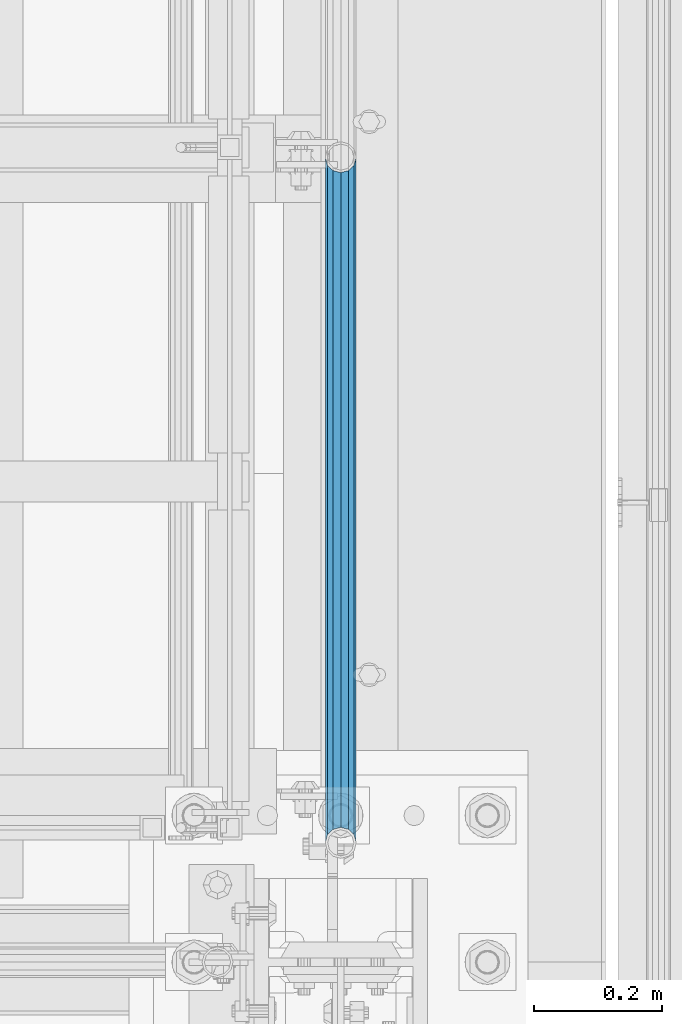
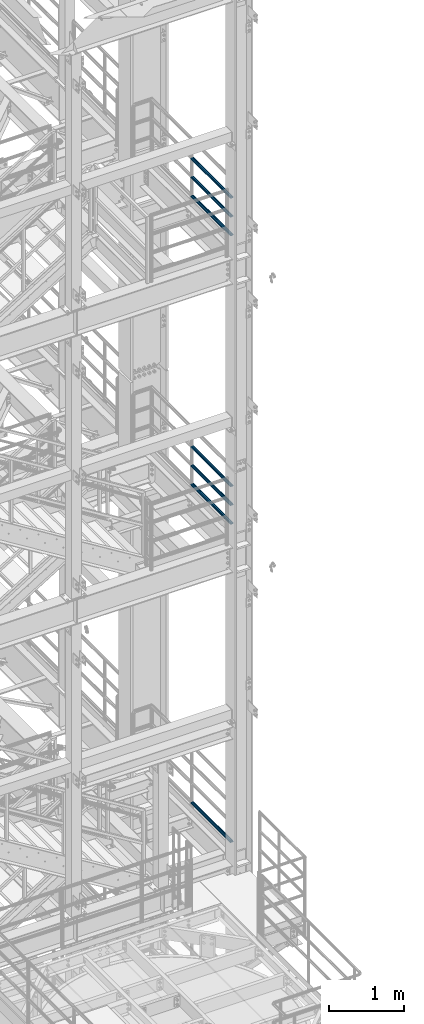
# One storey, part 999 of 1876: 7 beams, 3 elements without a shape of their own.
"""IFC2X3 building model written with IfcOpenShell, lengths in millimetres."""

from ifc_helpers import new_model, si_unit, frame, origin_with_axes, place, context, subcontext, project, spatial, faceted_brep, material, type_object, element, aggregate, save


model = new_model("IFC2X3")

# Units and contexts
model_context = context("Model", 3, precision=1e-05, world=origin_with_axes())
body_context = subcontext(model_context, "Body", "Model", "MODEL_VIEW")
ifc_project = project(units=[si_unit("LENGTHUNIT", "METRE", prefix="MILLI"), si_unit("AREAUNIT", "SQUARE_METRE"), si_unit("VOLUMEUNIT", "CUBIC_METRE"), si_unit("MASSUNIT", "GRAM", prefix="KILO"), si_unit("TIMEUNIT", "SECOND"), si_unit("PLANEANGLEUNIT", "RADIAN"), si_unit("SOLIDANGLEUNIT", "STERADIAN"), si_unit("THERMODYNAMICTEMPERATUREUNIT", "DEGREE_CELSIUS"), si_unit("LUMINOUSINTENSITYUNIT", "LUMEN")], contexts=[model_context])

# Site, building, storey
site_placement = place(None, origin_with_axes())
site = spatial("IfcSite", under=ifc_project, at=site_placement, CompositionType="ELEMENT")
building_placement = place(site_placement, origin_with_axes())
building = spatial("IfcBuilding", under=site, at=building_placement, Name="Undefined", CompositionType="ELEMENT")
storey_placement = place(building_placement, origin_with_axes())
storey = spatial("IfcBuildingStorey", under=building, at=storey_placement, Name="Undefined", CompositionType="ELEMENT", Elevation=0.0)

# Assembly, beams
assembly_1_placement = place(storey_placement, origin_with_axes())
assembly_1 = element("IfcElementAssembly", 1, at=assembly_1_placement, inside=storey, Name="RAIL", AssemblyPlace="NOTDEFINED", PredefinedType="RIGID_FRAME")
ifc_material = material()
beam_type = type_object("IfcBeamType", Name="PIPE1-1/2SCH40", PredefinedType="NOTDEFINED")
beam_1_placement = place(assembly_1_placement, frame((7620.00000000003, -5857.08124999999, 18145.125), z_axis=(0.0, 0.0, 1.0), x_axis=(0.0, -1.0, 0.0)))
beam_1 = element("IfcBeam", 2, at=beam_1_placement, type_object=beam_type, material=ifc_material, Name="RAIL", ObjectType="PIPE1-1/2SCH40", context=body_context, shape_type="Brep", body=[
    faceted_brep([(1047.96655700668, -12.0649999999996, 20.8971929933177), (1047.96655700668, -12.0649999999787, 15.8661214312015), (1047.47312856882, -10.2235000000001, 17.7076214311819), (1044.73375, 9.09494701772928e-13, 20.4470000000001), (1044.73375, 9.09494701772928e-13, 24.130000000001), (1047.47312856881, 10.2235000000001, 17.7076214311819), (1047.96655700668, 12.0650000000205, 15.8661214311578), (1047.96655700668, 12.0649999999996, 20.8971929933177), (1068.86375, 24.1300000000001, 0.0), (1056.79875, 20.8971929933186, 12.0649999999987), (1056.79875, 20.8971929933186, -12.0649999999987), (1053.60917843784, 17.7076214311801, 10.2235000000001), (1056.34855700666, 20.4470000000001, 0.0), (1053.60917843784, 17.7076214311801, -10.2235000000001), (1047.96655700668, 12.0650000000205, -15.8661214311578), (1047.96655700668, 12.0649999999996, -20.8971929933177), (1047.47312856881, 10.2235000000001, -17.7076214311819), (1044.73375, 0.0, -20.4470000000001), (1044.73375, 0.0, -24.130000000001), (1047.96655700668, -12.0649999999787, -15.8661214312015), (1047.96655700668, -12.0649999999996, -20.8971929933177), (1047.47312856882, -10.2235000000001, -17.7076214311819), (1068.86375, -24.1299999999792, 0.0), (1056.79875, -20.8971929933186, -12.0649999999987), (1056.79875, -20.8971929933186, 12.0649999999987), (1053.60917843788, -17.7076214311801, -10.2235000000001), (1056.3485570067, -20.4470000000001, 0.0), (1053.60917843788, -17.7076214311801, 10.2235000000001), (12.0650000000064, -20.8971929933177, -12.0649999999987), (20.8971929933249, -12.0650000000005, -20.8971929933177), (0.0, 24.1299999999992, 0.0), (12.0650000000064, 20.8971929933177, -12.0649999999987), (12.0650000000064, 20.8971929933177, 12.0649999999987), (20.8971929933249, 12.0650000000005, 20.8971929933177), (24.1300000000064, 0.0, 24.130000000001), (20.8971929933249, 12.0650000000005, -20.8971929933177), (24.1300000000063, 0.0, -24.130000000001), (24.1300000000063, 0.0, -20.4470000000001), (20.8971929933249, -12.0650000000005, -15.8661214311796), (21.3906214311868, -10.2235000000001, -17.7076214311819), (21.3906214311868, 10.2235000000001, -17.7076214311819), (20.8971929933249, 12.0650000000005, -15.8661214311796), (15.2545715621445, 17.7076214311801, -10.2235000000001), (12.5151929933249, 20.4470000000001, 0.0), (15.2545715621445, 17.7076214311801, 10.2235000000001), (20.8971929933249, 12.0650000000005, 15.8661214311796), (21.3906214311868, 10.2235000000001, 17.7076214311819), (24.1300000000064, 0.0, 20.4470000000001), (21.3906214311868, -10.2235000000001, 17.7076214311819), (20.8971929933249, -12.0650000000005, 15.8661214311796), (20.8971929933249, -12.0650000000005, 20.8971929933177), (12.0650000000064, -20.8971929933177, 12.0649999999987), (0.0, -24.1299999999992, 0.0), (15.2545715621445, -17.7076214311801, 10.2235000000001), (12.5151929933249, -20.4470000000001, 0.0), (15.2545715621445, -17.7076214311801, -10.2235000000001)], [[[0, 1, 2, 3, 4]], [[4, 3, 5, 6, 7]], [[8, 9, 10]], [[7, 6, 11, 12, 13, 14, 15, 10, 9]], [[16, 17, 18, 15, 14]], [[19, 20, 18, 17, 21]], [[22, 23, 24]], [[24, 23, 20, 19, 25, 26, 27, 1, 0]], [[28, 29, 20, 23]], [[30, 31, 32]], [[33, 34, 4, 7]], [[32, 33, 7, 9]], [[30, 32, 9, 8]], [[31, 30, 8, 10]], [[35, 31, 10, 15]], [[36, 35, 15, 18]], [[29, 36, 18, 20]], [[37, 36, 29, 38, 39]], [[40, 41, 35, 36, 37]], [[32, 31, 35, 41, 42, 43, 44, 45, 33]], [[33, 45, 46, 47, 34]], [[34, 47, 48, 49, 50]], [[34, 50, 0, 4]], [[50, 51, 24, 0]], [[51, 52, 22, 24]], [[52, 28, 23, 22]], [[51, 28, 52]], [[50, 49, 53, 54, 55, 38, 29, 28, 51]], [[55, 54, 26, 25]], [[21, 39, 38, 55, 25, 19]], [[37, 39, 21, 17]], [[40, 37, 17, 16]], [[42, 41, 40, 16, 14, 13]], [[43, 42, 13, 12]], [[44, 43, 12, 11]], [[5, 46, 45, 44, 11, 6]], [[47, 46, 5, 3]], [[48, 47, 3, 2]], [[53, 49, 48, 2, 1, 27]], [[54, 53, 27, 26]]]),
])
beam_2_placement = place(assembly_1_placement, frame((7620.00000000003, -6925.94499999999, 18449.925), z_axis=(0.0, 0.0, -1.0), x_axis=(0.0, 1.0, 0.0)))
beam_2 = element("IfcBeam", 3, at=beam_2_placement, type_object=beam_type, material=ifc_material, Name="RAIL", ObjectType="PIPE1-1/2SCH40", context=body_context, shape_type="Brep", body=[
    faceted_brep([(0.0, 24.1299999999992, 0.0), (12.0650000000064, 20.8971929933177, -12.0649999999987), (12.0650000000064, 20.8971929933177, 12.0649999999987), (12.0650000000064, -20.8971929933177, 12.0649999999987), (12.0650000000064, -20.8971929933177, -12.0649999999987), (0.0, -24.1299999999992, 0.0), (20.8971929933249, -12.0650000000005, 20.8971929933177), (20.8971929933249, -12.0650000000005, 15.8661214311796), (15.2545715621445, -17.7076214311801, 10.2235000000001), (12.5151929933249, -20.4470000000001, 0.0), (15.2545715621445, -17.7076214311801, -10.2235000000001), (20.8971929933249, -12.0650000000005, -15.8661214311796), (20.8971929933249, -12.0650000000005, -20.8971929933177), (24.1300000000063, 0.0, -20.4470000000001), (24.1300000000063, 0.0, -24.130000000001), (21.3906214311868, -10.2235000000001, -17.7076214311819), (21.3906214311868, 10.2235000000001, -17.7076214311819), (20.8971929933249, 12.0650000000005, -15.8661214311796), (20.8971929933249, 12.0650000000005, -20.8971929933177), (15.2545715621445, 17.7076214311801, -10.2235000000001), (12.5151929933249, 20.4470000000001, 0.0), (15.2545715621445, 17.7076214311801, 10.2235000000001), (20.8971929933249, 12.0650000000005, 15.8661214311796), (20.8971929933249, 12.0650000000005, 20.8971929933177), (21.3906214311868, 10.2235000000001, 17.7076214311819), (24.1300000000064, 0.0, 20.4470000000001), (24.1300000000064, 0.0, 24.130000000001), (21.3906214311868, -10.2235000000001, 17.7076214311819), (1068.86375, 24.1300000000001, 0.0), (1056.79875, 20.8971929933186, -12.0649999999987), (1047.96655700668, 12.0649999999996, -20.8971929933177), (1068.86375, -24.1299999999792, 0.0), (1056.79875, -20.8971929933186, -12.0649999999987), (1056.79875, -20.8971929933186, 12.0649999999987), (1047.96655700668, -12.0649999999996, 20.8971929933177), (1047.96655700668, -12.0649999999996, -20.8971929933177), (1044.73375, 0.0, -24.130000000001), (1047.47312856881, 10.2235000000001, -17.7076214311819), (1044.73375, 0.0, -20.4470000000001), (1047.96655700668, 12.0650000000205, -15.8661214311578), (1047.96655700668, -12.0649999999787, -15.8661214312015), (1047.47312856882, -10.2235000000001, -17.7076214311819), (1053.60917843788, -17.7076214311801, -10.2235000000001), (1056.3485570067, -20.4470000000001, 0.0), (1053.60917843788, -17.7076214311801, 10.2235000000001), (1047.96655700668, -12.0649999999787, 15.8661214312015), (1047.47312856882, -10.2235000000001, 17.7076214311819), (1044.73375, 9.09494701772928e-13, 20.4470000000001), (1044.73375, 9.09494701772928e-13, 24.130000000001), (1047.96655700668, 12.0649999999996, 20.8971929933177), (1056.79875, 20.8971929933186, 12.0649999999987), (1047.96655700668, 12.0650000000205, 15.8661214311578), (1053.60917843784, 17.7076214311801, 10.2235000000001), (1056.34855700666, 20.4470000000001, 0.0), (1053.60917843784, 17.7076214311801, -10.2235000000001), (1047.47312856881, 10.2235000000001, 17.7076214311819)], [[[0, 1, 2]], [[3, 4, 5]], [[6, 7, 8, 9, 10, 11, 12, 4, 3]], [[13, 14, 12, 11, 15]], [[16, 17, 18, 14, 13]], [[2, 1, 18, 17, 19, 20, 21, 22, 23]], [[23, 22, 24, 25, 26]], [[26, 25, 27, 7, 6]], [[1, 0, 28, 29]], [[18, 1, 29, 30]], [[31, 32, 33]], [[6, 3, 33, 34]], [[3, 5, 31, 33]], [[5, 4, 32, 31]], [[4, 12, 35, 32]], [[12, 14, 36, 35]], [[14, 18, 30, 36]], [[37, 38, 36, 30, 39]], [[40, 35, 36, 38, 41]], [[33, 32, 35, 40, 42, 43, 44, 45, 34]], [[34, 45, 46, 47, 48]], [[26, 6, 34, 48]], [[2, 23, 49, 50]], [[23, 26, 48, 49]], [[0, 2, 50, 28]], [[28, 50, 29]], [[49, 51, 52, 53, 54, 39, 30, 29, 50]], [[48, 47, 55, 51, 49]], [[25, 24, 55, 47]], [[55, 24, 22, 21, 52, 51]], [[21, 20, 53, 52]], [[20, 19, 54, 53]], [[19, 17, 16, 37, 39, 54]], [[16, 13, 38, 37]], [[13, 15, 41, 38]], [[41, 15, 11, 10, 42, 40]], [[10, 9, 43, 42]], [[9, 8, 44, 43]], [[8, 7, 27, 46, 45, 44]], [[27, 25, 47, 46]]]),
])
beam_3_placement = place(assembly_1_placement, frame((7620.00000000003, -6925.94499999999, 18754.725), z_axis=(0.0, 0.0, -1.0), x_axis=(0.0, 1.0, 0.0)))
beam_3 = element("IfcBeam", 4, at=beam_3_placement, type_object=beam_type, material=ifc_material, Name="RAIL", ObjectType="PIPE1-1/2SCH40", context=body_context, shape_type="Brep", body=[
    faceted_brep([(0.0, 24.1299999999992, 0.0), (12.0650000000064, 20.8971929933177, -12.0649999999987), (12.0650000000064, 20.8971929933177, 12.0649999999987), (12.0650000000064, -20.8971929933177, 12.0649999999987), (12.0650000000064, -20.8971929933177, -12.0649999999987), (0.0, -24.1299999999992, 0.0), (20.8971929933249, -12.0650000000005, 20.8971929933177), (20.8971929933249, -12.0650000000005, 15.8661214311796), (15.2545715621445, -17.7076214311801, 10.2235000000001), (12.5151929933249, -20.4470000000001, 0.0), (15.2545715621445, -17.7076214311801, -10.2235000000001), (20.8971929933249, -12.0650000000005, -15.8661214311796), (20.8971929933249, -12.0650000000005, -20.8971929933177), (24.1300000000063, 0.0, -20.4470000000001), (24.1300000000063, 0.0, -24.130000000001), (21.3906214311868, -10.2235000000001, -17.7076214311819), (21.3906214311868, 10.2235000000001, -17.7076214311819), (20.8971929933249, 12.0650000000005, -15.8661214311796), (20.8971929933249, 12.0650000000005, -20.8971929933177), (15.2545715621445, 17.7076214311801, -10.2235000000001), (12.5151929933249, 20.4470000000001, 0.0), (15.2545715621445, 17.7076214311801, 10.2235000000001), (20.8971929933249, 12.0650000000005, 15.8661214311796), (20.8971929933249, 12.0650000000005, 20.8971929933177), (21.3906214311868, 10.2235000000001, 17.7076214311819), (24.1300000000064, 0.0, 20.4470000000001), (24.1300000000064, 0.0, 24.130000000001), (21.3906214311868, -10.2235000000001, 17.7076214311819), (1068.86375, 24.1300000000001, 0.0), (1056.79875, 20.8971929933186, -12.0649999999987), (1047.96655700668, 12.0649999999996, -20.8971929933177), (1068.86375, -24.1299999999792, 0.0), (1056.79875, -20.8971929933186, -12.0649999999987), (1056.79875, -20.8971929933186, 12.0649999999987), (1047.96655700668, -12.0649999999996, 20.8971929933177), (1047.96655700668, -12.0649999999996, -20.8971929933177), (1044.73375, 0.0, -24.130000000001), (1047.47312856881, 10.2235000000001, -17.7076214311819), (1044.73375, 0.0, -20.4470000000001), (1047.96655700668, 12.0650000000205, -15.8661214311578), (1047.96655700668, -12.0649999999787, -15.8661214312015), (1047.47312856882, -10.2235000000001, -17.7076214311819), (1053.60917843788, -17.7076214311801, -10.2235000000001), (1056.3485570067, -20.4470000000001, 0.0), (1053.60917843788, -17.7076214311801, 10.2235000000001), (1047.96655700668, -12.0649999999787, 15.8661214312015), (1047.47312856882, -10.2235000000001, 17.7076214311819), (1044.73375, 9.09494701772928e-13, 20.4470000000001), (1044.73375, 9.09494701772928e-13, 24.130000000001), (1047.96655700668, 12.0649999999996, 20.8971929933177), (1056.79875, 20.8971929933186, 12.0649999999987), (1047.96655700668, 12.0650000000205, 15.8661214311578), (1053.60917843784, 17.7076214311801, 10.2235000000001), (1056.34855700666, 20.4470000000001, 0.0), (1053.60917843784, 17.7076214311801, -10.2235000000001), (1047.47312856881, 10.2235000000001, 17.7076214311819)], [[[0, 1, 2]], [[3, 4, 5]], [[6, 7, 8, 9, 10, 11, 12, 4, 3]], [[13, 14, 12, 11, 15]], [[16, 17, 18, 14, 13]], [[2, 1, 18, 17, 19, 20, 21, 22, 23]], [[23, 22, 24, 25, 26]], [[26, 25, 27, 7, 6]], [[1, 0, 28, 29]], [[18, 1, 29, 30]], [[31, 32, 33]], [[6, 3, 33, 34]], [[3, 5, 31, 33]], [[5, 4, 32, 31]], [[4, 12, 35, 32]], [[12, 14, 36, 35]], [[14, 18, 30, 36]], [[37, 38, 36, 30, 39]], [[40, 35, 36, 38, 41]], [[33, 32, 35, 40, 42, 43, 44, 45, 34]], [[34, 45, 46, 47, 48]], [[26, 6, 34, 48]], [[2, 23, 49, 50]], [[23, 26, 48, 49]], [[0, 2, 50, 28]], [[28, 50, 29]], [[49, 51, 52, 53, 54, 39, 30, 29, 50]], [[48, 47, 55, 51, 49]], [[25, 24, 55, 47]], [[55, 24, 22, 21, 52, 51]], [[21, 20, 53, 52]], [[20, 19, 54, 53]], [[19, 17, 16, 37, 39, 54]], [[16, 13, 38, 37]], [[13, 15, 41, 38]], [[41, 15, 11, 10, 42, 40]], [[10, 9, 43, 42]], [[9, 8, 44, 43]], [[8, 7, 27, 46, 45, 44]], [[27, 25, 47, 46]]]),
])
aggregate(assembly_1, [beam_1, beam_2, beam_3])

assembly_2_placement = place(storey_placement, origin_with_axes())
assembly_2 = element("IfcElementAssembly", 5, at=assembly_2_placement, inside=storey, Name="RAIL", AssemblyPlace="NOTDEFINED", PredefinedType="RIGID_FRAME")
beam_4_placement = place(assembly_2_placement, frame((7620.00000000003, -5857.08124999999, 13471.525), z_axis=(0.0, 0.0, 1.0), x_axis=(0.0, -1.0, 0.0)))
beam_4 = element("IfcBeam", 6, at=beam_4_placement, type_object=beam_type, material=ifc_material, Name="RAIL", ObjectType="PIPE1-1/2SCH40", context=body_context, shape_type="Brep", body=[
    faceted_brep([(1047.96655700668, -12.0649999999996, 20.8971929933177), (1047.96655700668, -12.0649999999787, 15.8661214312015), (1047.47312856882, -10.2235000000001, 17.7076214311819), (1044.73375, 9.09494701772928e-13, 20.4470000000001), (1044.73375, 9.09494701772928e-13, 24.130000000001), (1047.47312856881, 10.2235000000001, 17.7076214311819), (1047.96655700668, 12.0650000000205, 15.8661214311578), (1047.96655700668, 12.0649999999996, 20.8971929933177), (1068.86375, 24.1300000000001, 0.0), (1056.79875, 20.8971929933186, 12.0649999999987), (1056.79875, 20.8971929933186, -12.0649999999987), (1053.60917843784, 17.7076214311801, 10.2235000000001), (1056.34855700666, 20.4470000000001, 0.0), (1053.60917843784, 17.7076214311801, -10.2235000000001), (1047.96655700668, 12.0650000000205, -15.8661214311578), (1047.96655700668, 12.0649999999996, -20.8971929933177), (1047.47312856881, 10.2235000000001, -17.7076214311819), (1044.73375, 0.0, -20.4470000000001), (1044.73375, 0.0, -24.130000000001), (1047.96655700668, -12.0649999999787, -15.8661214312015), (1047.96655700668, -12.0649999999996, -20.8971929933177), (1047.47312856882, -10.2235000000001, -17.7076214311819), (1068.86375, -24.1299999999792, 0.0), (1056.79875, -20.8971929933186, -12.0649999999987), (1056.79875, -20.8971929933186, 12.0649999999987), (1053.60917843788, -17.7076214311801, -10.2235000000001), (1056.3485570067, -20.4470000000001, 0.0), (1053.60917843788, -17.7076214311801, 10.2235000000001), (12.0650000000064, -20.8971929933177, -12.0649999999987), (20.8971929933249, -12.0650000000005, -20.8971929933177), (0.0, 24.1299999999992, 0.0), (12.0650000000064, 20.8971929933177, -12.0649999999987), (12.0650000000064, 20.8971929933177, 12.0649999999987), (20.8971929933249, 12.0650000000005, 20.8971929933177), (24.1300000000064, 0.0, 24.130000000001), (20.8971929933249, 12.0650000000005, -20.8971929933177), (24.1300000000063, 0.0, -24.130000000001), (24.1300000000063, 0.0, -20.4470000000001), (20.8971929933249, -12.0650000000005, -15.8661214311796), (21.3906214311868, -10.2235000000001, -17.7076214311819), (21.3906214311868, 10.2235000000001, -17.7076214311819), (20.8971929933249, 12.0650000000005, -15.8661214311796), (15.2545715621445, 17.7076214311801, -10.2235000000001), (12.5151929933249, 20.4470000000001, 0.0), (15.2545715621445, 17.7076214311801, 10.2235000000001), (20.8971929933249, 12.0650000000005, 15.8661214311796), (21.3906214311868, 10.2235000000001, 17.7076214311819), (24.1300000000064, 0.0, 20.4470000000001), (21.3906214311868, -10.2235000000001, 17.7076214311819), (20.8971929933249, -12.0650000000005, 15.8661214311796), (20.8971929933249, -12.0650000000005, 20.8971929933177), (12.0650000000064, -20.8971929933177, 12.0649999999987), (0.0, -24.1299999999992, 0.0), (15.2545715621445, -17.7076214311801, 10.2235000000001), (12.5151929933249, -20.4470000000001, 0.0), (15.2545715621445, -17.7076214311801, -10.2235000000001)], [[[0, 1, 2, 3, 4]], [[4, 3, 5, 6, 7]], [[8, 9, 10]], [[7, 6, 11, 12, 13, 14, 15, 10, 9]], [[16, 17, 18, 15, 14]], [[19, 20, 18, 17, 21]], [[22, 23, 24]], [[24, 23, 20, 19, 25, 26, 27, 1, 0]], [[28, 29, 20, 23]], [[30, 31, 32]], [[33, 34, 4, 7]], [[32, 33, 7, 9]], [[30, 32, 9, 8]], [[31, 30, 8, 10]], [[35, 31, 10, 15]], [[36, 35, 15, 18]], [[29, 36, 18, 20]], [[37, 36, 29, 38, 39]], [[40, 41, 35, 36, 37]], [[32, 31, 35, 41, 42, 43, 44, 45, 33]], [[33, 45, 46, 47, 34]], [[34, 47, 48, 49, 50]], [[34, 50, 0, 4]], [[50, 51, 24, 0]], [[51, 52, 22, 24]], [[52, 28, 23, 22]], [[51, 28, 52]], [[50, 49, 53, 54, 55, 38, 29, 28, 51]], [[55, 54, 26, 25]], [[21, 39, 38, 55, 25, 19]], [[37, 39, 21, 17]], [[40, 37, 17, 16]], [[42, 41, 40, 16, 14, 13]], [[43, 42, 13, 12]], [[44, 43, 12, 11]], [[5, 46, 45, 44, 11, 6]], [[47, 46, 5, 3]], [[48, 47, 3, 2]], [[53, 49, 48, 2, 1, 27]], [[54, 53, 27, 26]]]),
])
beam_5_placement = place(assembly_2_placement, frame((7620.00000000003, -6925.94499999999, 13776.325), z_axis=(0.0, 0.0, -1.0), x_axis=(0.0, 1.0, 0.0)))
beam_5 = element("IfcBeam", 7, at=beam_5_placement, type_object=beam_type, material=ifc_material, Name="RAIL", ObjectType="PIPE1-1/2SCH40", context=body_context, shape_type="Brep", body=[
    faceted_brep([(0.0, 24.1299999999992, 0.0), (12.0650000000064, 20.8971929933177, -12.0649999999987), (12.0650000000064, 20.8971929933177, 12.0649999999987), (12.0650000000064, -20.8971929933177, 12.0649999999987), (12.0650000000064, -20.8971929933177, -12.0649999999987), (0.0, -24.1299999999992, 0.0), (20.8971929933249, -12.0650000000005, 20.8971929933177), (20.8971929933249, -12.0650000000005, 15.8661214311796), (15.2545715621445, -17.7076214311801, 10.2235000000001), (12.5151929933249, -20.4470000000001, 0.0), (15.2545715621445, -17.7076214311801, -10.2235000000001), (20.8971929933249, -12.0650000000005, -15.8661214311796), (20.8971929933249, -12.0650000000005, -20.8971929933177), (24.1300000000063, 0.0, -20.4470000000001), (24.1300000000063, 0.0, -24.130000000001), (21.3906214311868, -10.2235000000001, -17.7076214311819), (21.3906214311868, 10.2235000000001, -17.7076214311819), (20.8971929933249, 12.0650000000005, -15.8661214311796), (20.8971929933249, 12.0650000000005, -20.8971929933177), (15.2545715621445, 17.7076214311801, -10.2235000000001), (12.5151929933249, 20.4470000000001, 0.0), (15.2545715621445, 17.7076214311801, 10.2235000000001), (20.8971929933249, 12.0650000000005, 15.8661214311796), (20.8971929933249, 12.0650000000005, 20.8971929933177), (21.3906214311868, 10.2235000000001, 17.7076214311819), (24.1300000000064, 0.0, 20.4470000000001), (24.1300000000064, 0.0, 24.130000000001), (21.3906214311868, -10.2235000000001, 17.7076214311819), (1068.86375, 24.1300000000001, 0.0), (1056.79875, 20.8971929933186, -12.0649999999987), (1047.96655700668, 12.0649999999996, -20.8971929933177), (1068.86375, -24.1299999999792, 0.0), (1056.79875, -20.8971929933186, -12.0649999999987), (1056.79875, -20.8971929933186, 12.0649999999987), (1047.96655700668, -12.0649999999996, 20.8971929933177), (1047.96655700668, -12.0649999999996, -20.8971929933177), (1044.73375, 0.0, -24.130000000001), (1047.47312856881, 10.2235000000001, -17.7076214311819), (1044.73375, 0.0, -20.4470000000001), (1047.96655700668, 12.0650000000205, -15.8661214311578), (1047.96655700668, -12.0649999999787, -15.8661214312015), (1047.47312856882, -10.2235000000001, -17.7076214311819), (1053.60917843788, -17.7076214311801, -10.2235000000001), (1056.3485570067, -20.4470000000001, 0.0), (1053.60917843788, -17.7076214311801, 10.2235000000001), (1047.96655700668, -12.0649999999787, 15.8661214312015), (1047.47312856882, -10.2235000000001, 17.7076214311819), (1044.73375, 9.09494701772928e-13, 20.4470000000001), (1044.73375, 9.09494701772928e-13, 24.130000000001), (1047.96655700668, 12.0649999999996, 20.8971929933177), (1056.79875, 20.8971929933186, 12.0649999999987), (1047.96655700668, 12.0650000000205, 15.8661214311578), (1053.60917843784, 17.7076214311801, 10.2235000000001), (1056.34855700666, 20.4470000000001, 0.0), (1053.60917843784, 17.7076214311801, -10.2235000000001), (1047.47312856881, 10.2235000000001, 17.7076214311819)], [[[0, 1, 2]], [[3, 4, 5]], [[6, 7, 8, 9, 10, 11, 12, 4, 3]], [[13, 14, 12, 11, 15]], [[16, 17, 18, 14, 13]], [[2, 1, 18, 17, 19, 20, 21, 22, 23]], [[23, 22, 24, 25, 26]], [[26, 25, 27, 7, 6]], [[1, 0, 28, 29]], [[18, 1, 29, 30]], [[31, 32, 33]], [[6, 3, 33, 34]], [[3, 5, 31, 33]], [[5, 4, 32, 31]], [[4, 12, 35, 32]], [[12, 14, 36, 35]], [[14, 18, 30, 36]], [[37, 38, 36, 30, 39]], [[40, 35, 36, 38, 41]], [[33, 32, 35, 40, 42, 43, 44, 45, 34]], [[34, 45, 46, 47, 48]], [[26, 6, 34, 48]], [[2, 23, 49, 50]], [[23, 26, 48, 49]], [[0, 2, 50, 28]], [[28, 50, 29]], [[49, 51, 52, 53, 54, 39, 30, 29, 50]], [[48, 47, 55, 51, 49]], [[25, 24, 55, 47]], [[55, 24, 22, 21, 52, 51]], [[21, 20, 53, 52]], [[20, 19, 54, 53]], [[19, 17, 16, 37, 39, 54]], [[16, 13, 38, 37]], [[13, 15, 41, 38]], [[41, 15, 11, 10, 42, 40]], [[10, 9, 43, 42]], [[9, 8, 44, 43]], [[8, 7, 27, 46, 45, 44]], [[27, 25, 47, 46]]]),
])
beam_6_placement = place(assembly_2_placement, frame((7620.00000000003, -6925.94499999999, 14081.125), z_axis=(0.0, 0.0, -1.0), x_axis=(0.0, 1.0, 0.0)))
beam_6 = element("IfcBeam", 8, at=beam_6_placement, type_object=beam_type, material=ifc_material, Name="RAIL", ObjectType="PIPE1-1/2SCH40", context=body_context, shape_type="Brep", body=[
    faceted_brep([(0.0, 24.1299999999992, 0.0), (12.0650000000064, 20.8971929933177, -12.0649999999987), (12.0650000000064, 20.8971929933177, 12.0649999999987), (12.0650000000064, -20.8971929933177, 12.0649999999987), (12.0650000000064, -20.8971929933177, -12.0649999999987), (0.0, -24.1299999999992, 0.0), (20.8971929933249, -12.0650000000005, 20.8971929933177), (20.8971929933249, -12.0650000000005, 15.8661214311796), (15.2545715621445, -17.7076214311801, 10.2235000000001), (12.5151929933249, -20.4470000000001, 0.0), (15.2545715621445, -17.7076214311801, -10.2235000000001), (20.8971929933249, -12.0650000000005, -15.8661214311796), (20.8971929933249, -12.0650000000005, -20.8971929933177), (24.1300000000063, 0.0, -20.4470000000001), (24.1300000000063, 0.0, -24.130000000001), (21.3906214311868, -10.2235000000001, -17.7076214311819), (21.3906214311868, 10.2235000000001, -17.7076214311819), (20.8971929933249, 12.0650000000005, -15.8661214311796), (20.8971929933249, 12.0650000000005, -20.8971929933177), (15.2545715621445, 17.7076214311801, -10.2235000000001), (12.5151929933249, 20.4470000000001, 0.0), (15.2545715621445, 17.7076214311801, 10.2235000000001), (20.8971929933249, 12.0650000000005, 15.8661214311796), (20.8971929933249, 12.0650000000005, 20.8971929933177), (21.3906214311868, 10.2235000000001, 17.7076214311819), (24.1300000000064, 0.0, 20.4470000000001), (24.1300000000064, 0.0, 24.130000000001), (21.3906214311868, -10.2235000000001, 17.7076214311819), (1068.86375, 24.1300000000001, 0.0), (1056.79875, 20.8971929933186, -12.0649999999987), (1047.96655700668, 12.0649999999996, -20.8971929933177), (1068.86375, -24.1299999999792, 0.0), (1056.79875, -20.8971929933186, -12.0649999999987), (1056.79875, -20.8971929933186, 12.0649999999987), (1047.96655700668, -12.0649999999996, 20.8971929933177), (1047.96655700668, -12.0649999999996, -20.8971929933177), (1044.73375, 0.0, -24.130000000001), (1047.47312856881, 10.2235000000001, -17.7076214311819), (1044.73375, 0.0, -20.4470000000001), (1047.96655700668, 12.0650000000205, -15.8661214311578), (1047.96655700668, -12.0649999999787, -15.8661214312015), (1047.47312856882, -10.2235000000001, -17.7076214311819), (1053.60917843788, -17.7076214311801, -10.2235000000001), (1056.3485570067, -20.4470000000001, 0.0), (1053.60917843788, -17.7076214311801, 10.2235000000001), (1047.96655700668, -12.0649999999787, 15.8661214312015), (1047.47312856882, -10.2235000000001, 17.7076214311819), (1044.73375, 9.09494701772928e-13, 20.4470000000001), (1044.73375, 9.09494701772928e-13, 24.130000000001), (1047.96655700668, 12.0649999999996, 20.8971929933177), (1056.79875, 20.8971929933186, 12.0649999999987), (1047.96655700668, 12.0650000000205, 15.8661214311578), (1053.60917843784, 17.7076214311801, 10.2235000000001), (1056.34855700666, 20.4470000000001, 0.0), (1053.60917843784, 17.7076214311801, -10.2235000000001), (1047.47312856881, 10.2235000000001, 17.7076214311819)], [[[0, 1, 2]], [[3, 4, 5]], [[6, 7, 8, 9, 10, 11, 12, 4, 3]], [[13, 14, 12, 11, 15]], [[16, 17, 18, 14, 13]], [[2, 1, 18, 17, 19, 20, 21, 22, 23]], [[23, 22, 24, 25, 26]], [[26, 25, 27, 7, 6]], [[1, 0, 28, 29]], [[18, 1, 29, 30]], [[31, 32, 33]], [[6, 3, 33, 34]], [[3, 5, 31, 33]], [[5, 4, 32, 31]], [[4, 12, 35, 32]], [[12, 14, 36, 35]], [[14, 18, 30, 36]], [[37, 38, 36, 30, 39]], [[40, 35, 36, 38, 41]], [[33, 32, 35, 40, 42, 43, 44, 45, 34]], [[34, 45, 46, 47, 48]], [[26, 6, 34, 48]], [[2, 23, 49, 50]], [[23, 26, 48, 49]], [[0, 2, 50, 28]], [[28, 50, 29]], [[49, 51, 52, 53, 54, 39, 30, 29, 50]], [[48, 47, 55, 51, 49]], [[25, 24, 55, 47]], [[55, 24, 22, 21, 52, 51]], [[21, 20, 53, 52]], [[20, 19, 54, 53]], [[19, 17, 16, 37, 39, 54]], [[16, 13, 38, 37]], [[13, 15, 41, 38]], [[41, 15, 11, 10, 42, 40]], [[10, 9, 43, 42]], [[9, 8, 44, 43]], [[8, 7, 27, 46, 45, 44]], [[27, 25, 47, 46]]]),
])
aggregate(assembly_2, [beam_4, beam_5, beam_6])

# Assembly, beam
assembly_3_placement = place(storey_placement, origin_with_axes())
assembly_3 = element("IfcElementAssembly", 9, at=assembly_3_placement, inside=storey, Name="RAIL", AssemblyPlace="NOTDEFINED", PredefinedType="RIGID_FRAME")
beam_7_placement = place(assembly_3_placement, frame((7620.00000000003, -5857.08124999999, 8315.325), z_axis=(0.0, 0.0, 1.0), x_axis=(0.0, -1.0, 0.0)))
beam_7 = element("IfcBeam", 10, at=beam_7_placement, type_object=beam_type, material=ifc_material, Name="RAIL", ObjectType="PIPE1-1/2SCH40", context=body_context, shape_type="Brep", body=[
    faceted_brep([(1047.96655700668, -12.0649999999996, 20.8971929933177), (1047.96655700668, -12.0649999999787, 15.8661214312015), (1047.47312856882, -10.2235000000001, 17.7076214311819), (1044.73375, 9.09494701772928e-13, 20.4470000000001), (1044.73375, 9.09494701772928e-13, 24.130000000001), (1047.47312856881, 10.2235000000001, 17.7076214311819), (1047.96655700668, 12.0650000000205, 15.8661214311578), (1047.96655700668, 12.0649999999996, 20.8971929933177), (1068.86375, 24.1300000000001, 0.0), (1056.79875, 20.8971929933186, 12.0649999999987), (1056.79875, 20.8971929933186, -12.0649999999987), (1053.60917843784, 17.7076214311801, 10.2235000000001), (1056.34855700666, 20.4470000000001, 0.0), (1053.60917843784, 17.7076214311801, -10.2235000000001), (1047.96655700668, 12.0650000000205, -15.8661214311578), (1047.96655700668, 12.0649999999996, -20.8971929933177), (1047.47312856881, 10.2235000000001, -17.7076214311819), (1044.73375, 0.0, -20.4470000000001), (1044.73375, 0.0, -24.130000000001), (1047.96655700668, -12.0649999999787, -15.8661214312015), (1047.96655700668, -12.0649999999996, -20.8971929933177), (1047.47312856882, -10.2235000000001, -17.7076214311819), (1068.86375, -24.1299999999792, 0.0), (1056.79875, -20.8971929933186, -12.0649999999987), (1056.79875, -20.8971929933186, 12.0649999999987), (1053.60917843788, -17.7076214311801, -10.2235000000001), (1056.3485570067, -20.4470000000001, 0.0), (1053.60917843788, -17.7076214311801, 10.2235000000001), (12.0650000000064, -20.8971929933177, -12.0649999999987), (20.8971929933249, -12.0650000000005, -20.8971929933177), (0.0, 24.1299999999992, 0.0), (12.0650000000064, 20.8971929933177, -12.0649999999987), (12.0650000000064, 20.8971929933177, 12.0649999999987), (20.8971929933249, 12.0650000000005, 20.8971929933177), (24.1300000000064, 0.0, 24.130000000001), (20.8971929933249, 12.0650000000005, -20.8971929933177), (24.1300000000063, 0.0, -24.130000000001), (24.1300000000063, 0.0, -20.4470000000001), (20.8971929933249, -12.0650000000005, -15.8661214311796), (21.3906214311868, -10.2235000000001, -17.7076214311819), (21.3906214311868, 10.2235000000001, -17.7076214311819), (20.8971929933249, 12.0650000000005, -15.8661214311796), (15.2545715621445, 17.7076214311801, -10.2235000000001), (12.5151929933249, 20.4470000000001, 0.0), (15.2545715621445, 17.7076214311801, 10.2235000000001), (20.8971929933249, 12.0650000000005, 15.8661214311796), (21.3906214311868, 10.2235000000001, 17.7076214311819), (24.1300000000064, 0.0, 20.4470000000001), (21.3906214311868, -10.2235000000001, 17.7076214311819), (20.8971929933249, -12.0650000000005, 15.8661214311796), (20.8971929933249, -12.0650000000005, 20.8971929933177), (12.0650000000064, -20.8971929933177, 12.0649999999987), (0.0, -24.1299999999992, 0.0), (15.2545715621445, -17.7076214311801, 10.2235000000001), (12.5151929933249, -20.4470000000001, 0.0), (15.2545715621445, -17.7076214311801, -10.2235000000001)], [[[0, 1, 2, 3, 4]], [[4, 3, 5, 6, 7]], [[8, 9, 10]], [[7, 6, 11, 12, 13, 14, 15, 10, 9]], [[16, 17, 18, 15, 14]], [[19, 20, 18, 17, 21]], [[22, 23, 24]], [[24, 23, 20, 19, 25, 26, 27, 1, 0]], [[28, 29, 20, 23]], [[30, 31, 32]], [[33, 34, 4, 7]], [[32, 33, 7, 9]], [[30, 32, 9, 8]], [[31, 30, 8, 10]], [[35, 31, 10, 15]], [[36, 35, 15, 18]], [[29, 36, 18, 20]], [[37, 36, 29, 38, 39]], [[40, 41, 35, 36, 37]], [[32, 31, 35, 41, 42, 43, 44, 45, 33]], [[33, 45, 46, 47, 34]], [[34, 47, 48, 49, 50]], [[34, 50, 0, 4]], [[50, 51, 24, 0]], [[51, 52, 22, 24]], [[52, 28, 23, 22]], [[51, 28, 52]], [[50, 49, 53, 54, 55, 38, 29, 28, 51]], [[55, 54, 26, 25]], [[21, 39, 38, 55, 25, 19]], [[37, 39, 21, 17]], [[40, 37, 17, 16]], [[42, 41, 40, 16, 14, 13]], [[43, 42, 13, 12]], [[44, 43, 12, 11]], [[5, 46, 45, 44, 11, 6]], [[47, 46, 5, 3]], [[48, 47, 3, 2]], [[53, 49, 48, 2, 1, 27]], [[54, 53, 27, 26]]]),
])
aggregate(assembly_3, [beam_7])

save(model, "model.ifc")
